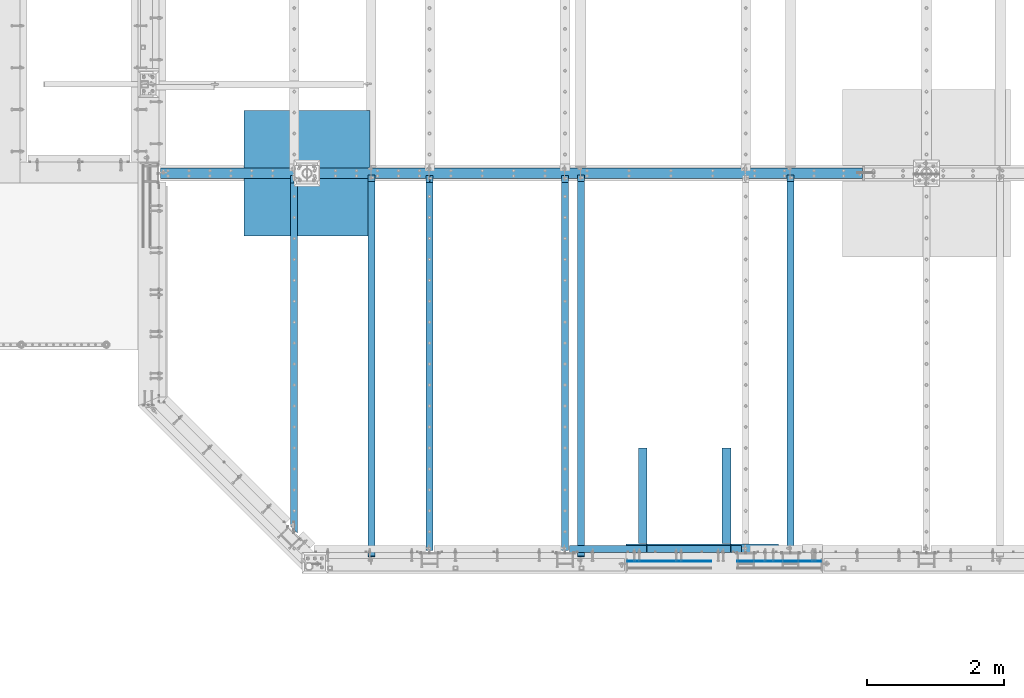
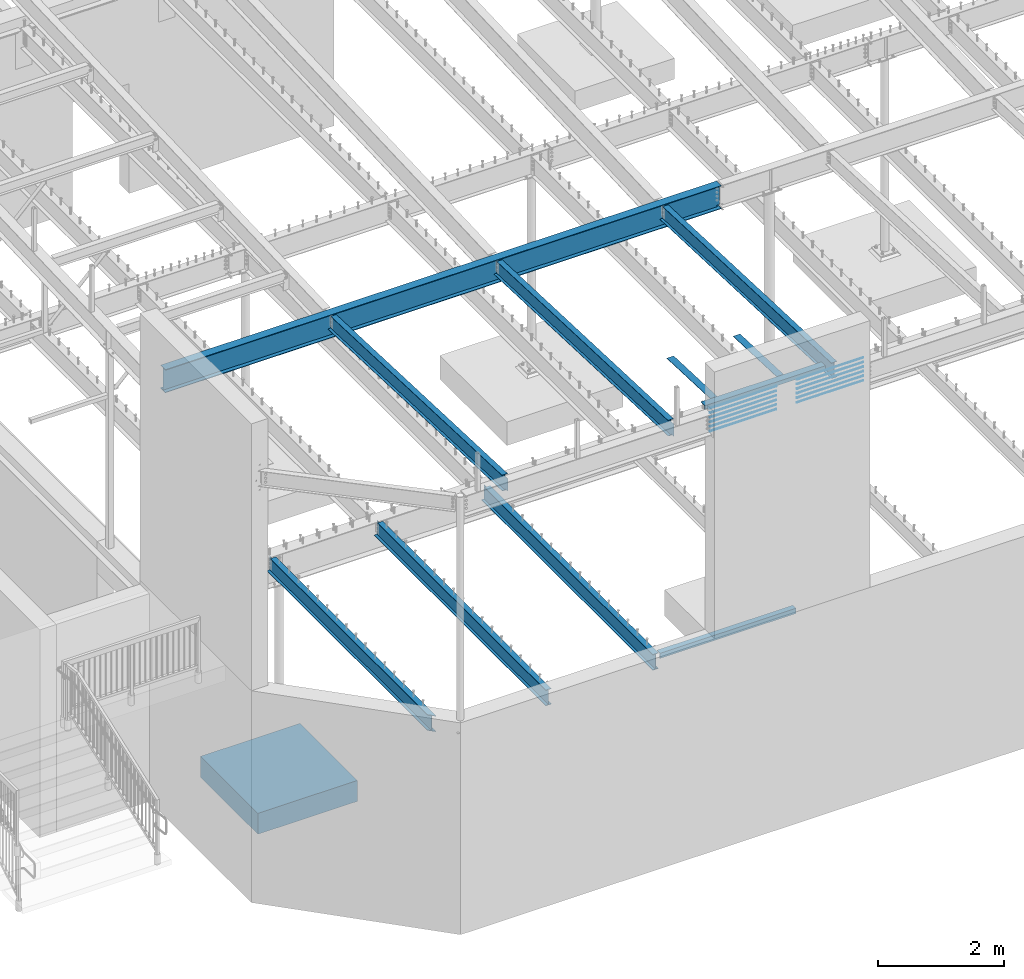
# One storey, part 310 of 975: 24 beams.
"""IFC2X3 building model written with IfcOpenShell, lengths in millimetres."""

from ifc_helpers import new_model, si_unit, frame, origin_with_axes, place, context, subcontext, project, spatial, faceted_brep, material, type_object, element, save


model = new_model("IFC2X3")

# Units and contexts
model_context = context("Model", 3, precision=1e-05, world=origin_with_axes())
body_context = subcontext(model_context, "Body", "Model", "MODEL_VIEW")
ifc_project = project(units=[si_unit("LENGTHUNIT", "METRE", prefix="MILLI"), si_unit("AREAUNIT", "SQUARE_METRE"), si_unit("VOLUMEUNIT", "CUBIC_METRE"), si_unit("MASSUNIT", "GRAM", prefix="KILO"), si_unit("TIMEUNIT", "SECOND"), si_unit("PLANEANGLEUNIT", "RADIAN"), si_unit("SOLIDANGLEUNIT", "STERADIAN"), si_unit("THERMODYNAMICTEMPERATUREUNIT", "DEGREE_CELSIUS"), si_unit("LUMINOUSINTENSITYUNIT", "LUMEN")], contexts=[model_context])

# Site, building, storey
site_placement = place(None, origin_with_axes())
site = spatial("IfcSite", under=ifc_project, at=site_placement, CompositionType="ELEMENT")
building_placement = place(site_placement, origin_with_axes())
building = spatial("IfcBuilding", under=site, at=building_placement, Name="Undefined", CompositionType="ELEMENT")
storey_placement = place(building_placement, origin_with_axes())
storey = spatial("IfcBuildingStorey", under=building, at=storey_placement, Name="Undefined", CompositionType="ELEMENT", Elevation=0.0)

# Beams
ifc_material_1 = material(Name="STEEL/A36")
beam_type_1 = type_object("IfcBeamType", Name="L4X4X5/16", PredefinedType="NOTDEFINED")
beam_1_placement = place(storey_placement, frame((8293.1, 355.6, 3886.2), z_axis=(0.0, 0.0, -1.0), x_axis=(1.0, 0.0, 0.0)))
element("IfcBeam", 1, at=beam_1_placement, inside=storey, type_object=beam_type_1, material=ifc_material_1, Name="LEDGER_ANGLE", ObjectType="L4X4X5/16", context=body_context, shape_type="Brep", body=[
    faceted_brep([(-1.90993887372315e-11, 50.8000000000002, -50.8), (2.00088834390044e-11, 50.8000000000002, 50.8), (2501.9, 50.8, 50.8000000000002), (2501.9, 50.8, -50.8000000000002), (2.00088834390044e-11, 42.8625000000002, 50.8), (2501.9, 42.8625, 50.8000000000002), (-1.63709046319127e-11, 42.8625000000002, -42.8625), (2501.9, 42.8625, -42.8625000000002), (-1.63709046319127e-11, -50.8000000000002, -42.8625), (2501.9, -50.8, -42.8625000000002), (-1.90993887372315e-11, -50.8000000000002, -50.8), (2501.9, -50.8, -50.8000000000002)], [[[0, 1, 2, 3]], [[1, 4, 5, 2]], [[4, 6, 7, 5]], [[6, 8, 9, 7]], [[8, 10, 11, 9]], [[10, 0, 3, 11]], [[5, 7, 9, 11, 3, 2]], [[10, 8, 6, 4, 1, 0]]]),
])
beam_type_2 = type_object("IfcBeamType", Name="L5X3X5/16", PredefinedType="NOTDEFINED")
for number, where, z_axis, x_axis, name in (
    (2, (9359.90074084503, 1826.04382111052, 8358.98196902733), (-0.999999999999998, 6.90000001668524e-08, 0.0), (-8.29999998634476e-08, -0.999194714570452, 0.0401238379827506), "ANGLE"),
    (3, (10579.1004373848, 1826.043922506, 8358.98196901953), (-0.999999999999998, 6.90000001668524e-08, 0.0), (-8.29999998634476e-08, -0.999194714570452, 0.0401238379827506), "ANGLE"),
):
    element("IfcBeam", number, at=place(storey_placement, frame(where, z_axis=z_axis, x_axis=x_axis)), inside=storey, type_object=beam_type_2, material=ifc_material_1, Name=name, ObjectType="L5X3X5/16", context=body_context, shape_type="Brep", body=[
        faceted_brep([(1395.30889729753, 38.1000000012609, 63.5000000006694), (1394.9901576922, 30.1625000012664, 63.5000000006712), (1394.99013793574, 30.1625000011627, -55.5624999993288), (1394.99013661864, 30.1625000322219, -63.4999999993288), (1395.30887618999, 38.1000000011518, -63.4999999993306), (1501.2669859932, 25.8948292101068, -55.562499999276), (1501.2669846761, 25.8948292629557, -63.499999999276), (1513.45074109103, 12.6953416428732, -55.5624999992651), (1513.45073977393, 12.695341695724, -63.4999999992651), (1511.42524778765, -38.0999999987016, -55.5624999992524), (1511.42524647055, -38.0999999987089, -63.4999999992524), (5.0931703299284e-11, -38.0999999999999, -63.5000000000255), (2.27373675443232e-12, -38.1000000000313, -55.5624999999873), (3.41060513164848e-12, 30.1624999999367, -55.5625000000091), (-3.63797880709171e-12, 30.1625000000404, 63.4999999999909), (-4.72937244921923e-11, 38.0999999999999, 63.5000000000182), (5.0931703299284e-11, 38.0999999999999, -63.5000000000255)], [[[0, 1, 2, 3, 4]], [[5, 6, 3, 2]], [[7, 8, 6, 5]], [[9, 10, 8, 7]], [[11, 12, 13, 14, 15, 16]], [[14, 13, 2, 1]], [[15, 14, 1, 0]], [[16, 15, 0, 4]], [[11, 16, 4, 3, 6, 8, 10]], [[12, 11, 10, 9]], [[2, 13, 12, 9, 7, 5]]]),
    ])
beam_2_placement = place(storey_placement, frame((11331.574981802, 368.300247296049, 8420.1), z_axis=(0.0, 1.0, 0.0), x_axis=(-0.999999999999998, 6.90000001668524e-08, 0.0)))
element("IfcBeam", 4, at=beam_2_placement, inside=storey, type_object=beam_type_2, material=ifc_material_1, Name="LEDGER_ANGLE", ObjectType="L5X3X5/16", context=body_context, shape_type="Brep", body=[
    faceted_brep([(5.0931703299284e-11, 38.0999999999999, -63.5000000000255), (-4.72937244921923e-11, 38.0999999999999, 63.5000000000182), (2212.9749747635, 38.1000000000004, 63.4999999999912), (2212.97497476345, 38.1000000000004, -63.5000000000088), (-3.63797880709171e-12, 30.1625000000404, 63.4999999999909), (2212.9749747635, 30.1625000000004, 63.4999999999912), (3.41060513164848e-12, 30.1624999999367, -55.5625000000091), (2212.97497476345, 30.1625000000004, -55.5625000000088), (2.27373675443232e-12, -38.1000000000313, -55.5624999999873), (2212.97497476345, -38.1000000000004, -55.5625000000088), (5.0931703299284e-11, -38.0999999999999, -63.5000000000255), (2212.97497476345, -38.1000000000004, -63.5000000000088)], [[[0, 1, 2, 3]], [[1, 4, 5, 2]], [[4, 6, 7, 5]], [[6, 8, 9, 7]], [[8, 10, 11, 9]], [[10, 0, 3, 11]], [[5, 7, 9, 11, 3, 2]], [[10, 8, 6, 4, 1, 0]]]),
])
ifc_material_2 = material(Name="STEEL/A496")
beam_type_3 = type_object("IfcBeamType", Name="#6 DBA", PredefinedType="NOTDEFINED")
for number, where, z_axis, x_axis, name in (
    (5, (11953.8750023398, 177.800001625287, 8389.94743098933), (0.0, 1.0, 0.0), (-0.999999999999998, 6.90000001668524e-08, 0.0), "ROD"),
    (6, (11953.8750023398, 177.800001607478, 8301.04744311368), (0.0, 1.0, 0.0), (-0.999999999999998, 6.90000001668524e-08, 0.0), "ROD"),
    (7, (11953.8750023398, 177.800001589665, 8212.14745523802), (0.0, 1.0, 0.0), (-0.999999999999998, 6.90000001668524e-08, 0.0), "ROD"),
    (8, (11953.8750023398, 177.800001571856, 8123.24746736236), (0.0, 1.0, 0.0), (-0.999999999999998, 6.90000001668524e-08, 0.0), "ROD"),
    (9, (11953.8750023398, 177.800001554044, 8034.3474794867), (0.0, 1.0, 0.0), (-0.999999999999998, 6.90000001668524e-08, 0.0), "ROD"),
    (10, (11953.8750023398, 177.800001643099, 8478.84741886499), (0.0, 1.0, 0.0), (-0.999999999999998, 6.90000001668524e-08, 0.0), "ROD"),
    (11, (9137.65001562954, 177.799615470926, 8389.94750201357), (0.0, -1.0, 0.0), (1.0, 0.0, 0.0), "ROD"),
    (12, (9137.65001562954, 177.799615488735, 8301.04751413792), (0.0, -1.0, 0.0), (1.0, 0.0, 0.0), "ROD"),
    (13, (9137.65001562954, 177.799615506548, 8212.14752626226), (0.0, -1.0, 0.0), (1.0, 0.0, 0.0), "ROD"),
    (14, (9137.65001562954, 177.799615524357, 8123.2475383866), (0.0, -1.0, 0.0), (1.0, 0.0, 0.0), "ROD"),
    (15, (9137.65001562954, 177.79961554217, 8034.34755051095), (0.0, -1.0, 0.0), (1.0, 0.0, 0.0), "ROD"),
    (16, (9137.6699008948, 177.799615451463, 8478.84748988923), (0.0, -1.0, 0.0), (1.0, 0.0, 0.0), "ROD"),
):
    element("IfcBeam", number, at=place(storey_placement, frame(where, z_axis=z_axis, x_axis=x_axis)), inside=storey, type_object=beam_type_3, material=ifc_material_2, Name=name, ObjectType="#6 DBA", context=body_context, shape_type="Brep", body=[
        faceted_brep([(0.0, -6.34999999998763, -3.63797880709171e-12), (0.0, -4.49012806052269, -4.49012806054634), (1219.19983372321, -4.49012806053543, -4.49012805836537), (1219.19983372321, -6.35000000000036, 2.16823536902666e-09), (0.0, 7.27595761418343e-12, -6.35000000000764), (1219.19983372321, 0.0, -6.34999999783395), (0.0, 4.49012806053724, -4.49012806053906), (1219.19983372321, 4.49012806053543, -4.49012805836537), (0.0, 6.34999999999491, 5.45696821063757e-12), (1219.19983372321, 6.35000000000036, 2.16823536902666e-09), (0.0, 4.49012806052633, 4.49012806054634), (1219.19983372321, 4.49012806053543, 4.49012806270184), (0.0, 0.0, 6.35000000000764), (1219.19983372321, 0.0, 6.35000000216678), (0.0, -4.49012806053361, 4.49012806053543), (1219.19983372321, -4.49012806053543, 4.49012806270184)], [[[0, 1, 2, 3]], [[1, 4, 5, 2]], [[4, 6, 7, 5]], [[6, 8, 9, 7]], [[8, 10, 11, 9]], [[10, 12, 13, 11]], [[12, 14, 15, 13]], [[14, 0, 3, 15]], [[5, 7, 9, 11, 13, 15, 3, 2]], [[14, 12, 10, 8, 6, 4, 1, 0]]]),
    ])
ifc_material_3 = material(Name="STEEL/A992")
beam_type_4 = type_object("IfcBeamType", Name="W12X14", PredefinedType="NOTDEFINED")
beam_3_placement = place(storey_placement, frame((11509.375, 298.74906253854, 8300.36917188875), z_axis=(0.0, 0.0401238250036801, 0.999194715091645), x_axis=(0.0, 0.999194715091645, -0.0401238250036801)))
element("IfcBeam", 17, at=beam_3_placement, inside=storey, type_object=beam_type_4, material=ifc_material_3, Name="BEAM", ObjectType="W12X14", context=body_context, shape_type="Brep", body=[
    faceted_brep([(37.277581501579, -2.38124999999854, -144.462500000039), (37.277581501579, -50.7999999999993, -144.462500000039), (5505.06171865214, -50.7999999999993, -144.462499998078), (5505.06171865214, -2.38125000000036, -144.462499998078), (37.5325731312614, -50.7999999999993, -150.812500000041), (5505.31671028182, -50.7999999999993, -150.812499998081), (37.5325731312614, 50.7999999999993, -150.812500000041), (5505.31671028182, 50.7999999999993, -150.812499998081), (37.277581501579, 50.7999999999993, -144.462500000039), (37.277581501579, 2.38124999999854, -144.462500000039), (5505.06171865214, 2.38125000000036, -144.462499998078), (5505.06171865214, 50.7999999999993, -144.462499998078), (5494.47956601909, 2.38125000000036, 119.062500032711), (5494.47956601909, -2.38125000000036, 119.062500032711), (25.6754623510329, -2.38124999999854, 144.462500000065), (25.6754623510329, -50.7999999999993, 144.462500000065), (25.4204707213506, -50.7999999999993, 150.812500000067), (25.4204707213506, 50.7999999999993, 150.812500000067), (25.6754623510329, 50.7999999999993, 144.462500000065), (25.6754623510329, 2.38124999999854, 144.462500000065), (5403.71671028046, 50.7999999999993, 144.462500001993), (5403.71671028046, 2.38125000000036, 144.462500001993), (5403.71671028046, 2.38125000000036, 131.762499841952), (5404.68344020305, 2.38125000000036, 126.902420323901), (5407.43645410352, 2.38125000000036, 122.782243855745), (5411.55663057168, 2.38125000000036, 120.029229955266), (5416.41671008973, 2.38125000000036, 119.06250003268), (5404.68344020305, -2.38125000000036, 126.902420323901), (5403.71671028046, -2.38125000000036, 131.762499841952), (5407.43645410352, -2.38125000000036, 122.782243855745), (5411.55663057168, -2.38125000000036, 120.029229955266), (5416.41671008973, -2.38125000000036, 119.06250003268), (5403.71671028046, -2.38125000000036, 144.462500001993), (5403.71671028046, -50.7999999999993, 144.462500001993), (5403.71671028046, -50.7999999999993, 150.812500001995), (5403.71671028046, 50.7999999999993, 150.812500001995)], [[[0, 1, 2, 3]], [[1, 4, 5, 2]], [[4, 6, 7, 5]], [[8, 9, 10, 11]], [[3, 2, 5, 7, 11, 10, 12, 13]], [[6, 8, 11, 7]], [[4, 1, 0, 14, 15, 16, 17, 18, 19, 9, 8, 6]], [[19, 18, 20, 21]], [[10, 9, 19, 21, 22, 23, 24, 25, 26, 12]], [[27, 23, 22, 28]], [[29, 24, 23, 27]], [[30, 25, 24, 29]], [[31, 26, 25, 30]], [[13, 12, 26, 31]], [[30, 29, 27, 28, 32, 14, 0, 3, 13, 31]], [[15, 14, 32, 33]], [[16, 15, 33, 34]], [[17, 16, 34, 35]], [[18, 17, 35, 20]], [[34, 33, 32, 28, 22, 21, 20, 35]]]),
])
beam_4_placement = place(storey_placement, frame((8461.375, 95.5756617602171, 8307.50787178829), z_axis=(0.0, 0.039945880990807, 0.999201844770049), x_axis=(0.0, 0.999201844770049, -0.039945880990807)))
element("IfcBeam", 18, at=beam_4_placement, inside=storey, type_object=beam_type_4, material=ifc_material_3, Name="BEAM", ObjectType="W12X14", context=body_context, shape_type="Brep", body=[
    faceted_brep([(62.4236399004201, -2.38125000000036, -119.062500005292), (62.4236402960233, 2.38125000000036, -119.062500005293), (140.53463013612, 2.38125000000036, -119.062500005381), (140.53463013612, -2.38125000000036, -119.062500005381), (145.394709654166, 2.38125000000036, -120.029229927974), (145.394709654166, -2.38125000000036, -120.029229927974), (149.514886122322, 2.38125000000036, -122.782243828455), (149.514886122322, -2.38125000000036, -122.782243828455), (152.267900022804, 2.38125000000036, -126.902420296611), (152.267900022804, -2.38125000000036, -126.902420296611), (153.234629945395, -2.38125000000036, -131.762499814659), (153.234629945395, 2.38125000000036, -131.762499814659), (153.234629945398, 2.38125000000036, -144.46250000013), (153.234629945397, 50.7999999999993, -144.46250000013), (153.234629945398, 50.7999999999993, -150.81250000013), (153.234629945398, -50.7999999999993, -150.81250000013), (153.234629945397, -50.7999999999993, -144.46250000013), (153.234629945397, -2.38125000000036, -144.46250000013), (5606.98626440076, 50.7999999999993, 144.462499995676), (5606.98626440076, 2.38125000000036, 144.462499995676), (153.234629945373, 2.38125000000036, 144.462499999896), (153.234629945373, 50.7999999999993, 144.462499999896), (140.534630136153, -2.38125000000036, 119.06249999471), (140.534630136153, 2.38125000000036, 119.06249999471), (52.9039291776887, 2.38125000000036, 119.06249999471), (52.9039287820855, -2.38125000000036, 119.062499994712), (145.394709654198, -2.38125000000036, 120.029229917291), (145.394709654198, 2.38125000000036, 120.029229917291), (149.51488612235, -2.38125000000036, 122.782243817765), (149.51488612235, 2.38125000000036, 122.782243817765), (152.267900022825, -2.38125000000036, 126.902420285916), (152.267900022825, 2.38125000000036, 126.902420285916), (153.234629945409, -2.38125000000036, 131.762499803961), (153.234629945409, 2.38125000000036, 131.762499803961), (5606.98626440077, -50.7999999999993, 150.812499995676), (5606.98626440077, 50.7999999999993, 150.812499995676), (153.234629945377, 50.7999999999993, 150.812499999898), (153.234629945377, -50.7999999999993, 150.812499810147), (5606.98626440076, -50.7999999999993, 144.462499995676), (153.234629945373, -50.7999999999993, 144.462499999896), (5606.98626440076, -2.38125000000036, 144.462499995676), (153.234629945373, -2.38125000000036, 144.462499999896), (5606.9862644008, -2.38125000000036, 131.762499785807), (5606.9862644008, 2.38125000000036, 131.762499785807), (5607.9529943234, -2.38125000000036, 126.902420267759), (5607.9529943234, 2.38125000000036, 126.902420267759), (5610.70600822388, -2.38125000000036, 122.782243799602), (5610.70600822388, 2.38125000000036, 122.782243799602), (5614.82618469204, -2.38125000000036, 120.029229899115), (5614.82618469204, 2.38125000000036, 120.029229899115), (5619.68626421008, -2.38125000000036, 119.06249997652), (5619.68626421008, 2.38125000000036, 119.06249997652), (5697.79725846631, -2.38125000000036, 119.062499976533), (5697.79725846631, 2.38125000000036, 119.062499976533), (5708.3324054365, -2.38125000000036, -144.46250000443), (5708.3324054365, -50.7999999999993, -144.46250000443), (5708.58626439966, -50.7999999999993, -150.81250000443), (5708.58626439966, 50.7999999999993, -150.81250000443), (5708.3324054365, 50.7999999999993, -144.46250000443), (5708.3324054365, 2.38125000000036, -144.46250000443)], [[[0, 1, 2, 3]], [[3, 2, 4, 5]], [[5, 4, 6, 7]], [[7, 6, 8, 9]], [[10, 11, 12, 13, 14, 15, 16, 17]], [[9, 8, 11, 10]], [[18, 19, 20, 21]], [[22, 23, 24, 25]], [[26, 27, 23, 22]], [[28, 29, 27, 26]], [[30, 31, 29, 28]], [[32, 33, 31, 30]], [[34, 35, 36, 37]], [[38, 34, 37, 39]], [[40, 38, 39, 41]], [[37, 36, 21, 20, 33, 32, 41, 39]], [[35, 18, 21, 36]], [[34, 38, 40, 42, 43, 19, 18, 35]], [[44, 45, 43, 42]], [[46, 47, 45, 44]], [[48, 49, 47, 46]], [[50, 51, 49, 48]], [[52, 53, 51, 50]], [[54, 55, 56, 57, 58, 59, 53, 52]], [[55, 54, 17, 16]], [[56, 55, 16, 15]], [[57, 56, 15, 14]], [[58, 57, 14, 13]], [[59, 58, 13, 12]], [[6, 4, 2, 1, 24, 23, 27, 29, 31, 33, 20, 19, 43, 45, 47, 49, 51, 53, 59, 12, 11, 8]], [[25, 24, 1, 0]], [[54, 52, 50, 48, 46, 44, 42, 40, 41, 32, 30, 28, 26, 22, 25, 0, 3, 5, 7, 9, 10, 17]]]),
])
beam_5_placement = place(storey_placement, frame((5413.375, 95.5756617602171, 8307.50787178829), z_axis=(0.0, 0.039945880990807, 0.999201844770049), x_axis=(0.0, 0.999201844770049, -0.039945880990807)))
element("IfcBeam", 19, at=beam_5_placement, inside=storey, type_object=beam_type_4, material=ifc_material_3, Name="BEAM", ObjectType="W12X14", context=body_context, shape_type="Brep", body=[
    faceted_brep([(62.4238930863233, -2.38125000000036, -119.062500000818), (62.4238934819265, 2.38125000000036, -119.062500000819), (140.534883321403, 2.38125000000036, -119.062500000907), (140.534883321403, -2.38125000000036, -119.062500000907), (145.394962839449, 2.38125000000036, -120.029229923498), (145.394962839449, -2.38125000000036, -120.029229923498), (149.515139307605, 2.38125000000036, -122.782243823979), (149.515139307605, -2.38125000000036, -122.782243823979), (152.268153208086, 2.38125000000036, -126.902420292136), (152.268153208086, -2.38125000000036, -126.902420292136), (153.234883130678, -2.38125000000036, -131.762499810184), (153.234883130678, 2.38125000000036, -131.762499810184), (153.234883130679, 2.38125000000036, -144.462500000131), (153.23488313068, 50.8000000000002, -144.462500000131), (153.234883130681, 50.8000000000002, -150.812500000131), (153.23488313068, -50.8000000000002, -150.812500000131), (153.234883130679, -50.8000000000002, -144.462500000131), (153.23488313068, -2.38125000000036, -144.462500000131), (5606.98626440076, 50.7999999999993, 144.462499995676), (5606.98626440076, 2.38125000000036, 144.462499995676), (153.234883130655, 2.38125000000036, 144.462499999898), (153.234883130655, 50.8000000000002, 144.462499999898), (140.534883321436, -2.38125000000036, 119.062499999187), (140.534883321436, 2.38125000000036, 119.062499999187), (52.9041823635919, 2.38125000000036, 119.062499999187), (52.9041819679886, -2.38125000000036, 119.062499999187), (145.394962839481, -2.38125000000036, 120.029229921767), (145.394962839481, 2.38125000000036, 120.029229921767), (149.515139307633, -2.38125000000036, 122.782243822237), (149.515139307633, 2.38125000000036, 122.782243822237), (152.268153208108, -2.38125000000036, 126.902420290389), (152.268153208108, 2.38125000000036, 126.902420290389), (153.234883130692, -2.38125000000036, 131.762499808436), (153.234883130692, 2.38125000000036, 131.762499808436), (5606.98626440077, -50.7999999999993, 150.812499995676), (5606.98626440077, 50.7999999999993, 150.812499995676), (153.23488313066, 50.8000000000002, 150.812499999898), (153.23488313066, -50.8000000000002, 150.812499810145), (5606.98626440076, -50.7999999999993, 144.462499995676), (153.234883130655, -50.8000000000002, 144.462499999898), (5606.98626440076, -2.38125000000036, 144.462499995676), (153.234883130655, -2.38125000000036, 144.462499999898), (5606.9862644008, -2.38125000000036, 131.762499785807), (5606.9862644008, 2.38125000000036, 131.762499785807), (5607.9529943234, -2.38125000000036, 126.902420267759), (5607.9529943234, 2.38125000000036, 126.902420267759), (5610.70600822388, -2.38125000000036, 122.782243799602), (5610.70600822388, 2.38125000000036, 122.782243799602), (5614.82618469204, -2.38125000000036, 120.029229899115), (5614.82618469204, 2.38125000000036, 120.029229899115), (5619.68626421008, -2.38125000000036, 119.06249997652), (5619.68626421008, 2.38125000000036, 119.06249997652), (5697.79725846631, -2.38125000000036, 119.062499976533), (5697.79725846631, 2.38125000000036, 119.062499976533), (5708.3324054365, -2.38125000000036, -144.46250000443), (5708.3324054365, -50.7999999999993, -144.46250000443), (5708.58626439966, -50.7999999999993, -150.81250000443), (5708.58626439966, 50.7999999999993, -150.81250000443), (5708.3324054365, 50.7999999999993, -144.46250000443), (5708.3324054365, 2.38125000000036, -144.46250000443)], [[[0, 1, 2, 3]], [[3, 2, 4, 5]], [[5, 4, 6, 7]], [[7, 6, 8, 9]], [[10, 11, 12, 13, 14, 15, 16, 17]], [[9, 8, 11, 10]], [[18, 19, 20, 21]], [[22, 23, 24, 25]], [[26, 27, 23, 22]], [[28, 29, 27, 26]], [[30, 31, 29, 28]], [[32, 33, 31, 30]], [[34, 35, 36, 37]], [[38, 34, 37, 39]], [[40, 38, 39, 41]], [[37, 36, 21, 20, 33, 32, 41, 39]], [[35, 18, 21, 36]], [[34, 38, 40, 42, 43, 19, 18, 35]], [[44, 45, 43, 42]], [[46, 47, 45, 44]], [[48, 49, 47, 46]], [[50, 51, 49, 48]], [[52, 53, 51, 50]], [[54, 55, 56, 57, 58, 59, 53, 52]], [[55, 54, 17, 16]], [[56, 55, 16, 15]], [[57, 56, 15, 14]], [[58, 57, 14, 13]], [[59, 58, 13, 12]], [[6, 4, 2, 1, 24, 23, 27, 29, 31, 33, 20, 19, 43, 45, 47, 49, 51, 53, 59, 12, 11, 8]], [[25, 24, 1, 0]], [[54, 52, 50, 48, 46, 44, 42, 40, 41, 32, 30, 28, 26, 22, 25, 0, 3, 5, 7, 9, 10, 17]]]),
])
beam_type_5 = type_object("IfcBeamType", Name="W18X35", PredefinedType="NOTDEFINED")
beam_6_placement = place(storey_placement, frame((2320.92509301436, 5819.775, 8004.175), z_axis=(0.0, 0.0, 1.0), x_axis=(1.0, 0.0, 0.0)))
element("IfcBeam", 20, at=beam_6_placement, inside=storey, type_object=beam_type_5, material=ifc_material_3, Name="BEAM", ObjectType="W18X35", context=body_context, shape_type="Brep", body=[
    faceted_brep([(10249.2969231633, -3.96875, 213.915499496458), (10249.2969231633, 3.96875, 213.915499496458), (10248.8999382805, 3.96875, 214.312499999999), (10248.8999382805, 76.1999999999998, 214.312499999999), (10237.787875523, 76.1999999999998, 225.425), (10237.787875523, -76.1999999999998, 225.425), (10248.8999382805, -76.1999999999998, 214.312499999999), (10248.8999382805, -3.96875, 214.312499999999), (25.3999999999992, -76.1999999999998, -225.425), (25.3999999999992, -76.1999999999998, -214.3125), (25.3999999999992, -3.96875, -214.3125), (25.3999999999992, -3.96875, 214.312499999999), (25.3999999999992, -76.1999999999998, 214.312499999999), (25.3999999999992, -76.1999999999998, 225.425), (25.3999999999992, 76.1999999999998, 225.425), (25.3999999999992, 76.1999999999998, 214.312499999999), (25.3999999999992, 3.96875, 214.312499999999), (25.3999999999992, 3.96875, -214.3125), (25.3999999999992, 76.1999999999998, -214.3125), (25.3999999999992, 76.1999999999998, -225.425), (10237.7878759883, 3.96875, -214.3125), (10237.7878759883, 76.1999999999998, -214.3125), (10248.8999387459, 76.1999999999998, -225.425), (10248.8999387459, -76.1999999999998, -225.425), (10237.7878759883, -76.1999999999998, -214.3125), (10237.7878759883, -3.96875, -214.3125), (10237.3908911055, 3.96875, -213.91549949646), (10237.3908911055, -3.96875, -213.91549949646), (10217.9439075044, 3.96875, -213.91549949646), (10217.9439075044, -3.96875, -213.91549949646), (10199.4566399626, 3.96875, -203.575605287907), (10199.4566399626, -3.96875, -203.575605287907), (10195.3439548054, 3.96875, -198.997422721185), (10195.3439548054, -3.96875, -198.997422721185), (10194.8890964811, 3.96875, -192.860074863893), (10194.8890964811, -3.96875, -192.860074863893), (10198.2819482329, 3.96875, -187.72563314086), (10198.2819482329, -3.96875, -187.72563314086), (10204.1061444376, 3.96875, -185.7375), (10204.1061444376, -3.96875, -185.7375), (10245.7249069856, 3.96875, -185.7375), (10245.7249069856, -3.96875, -185.7375), (10245.7249069856, -3.96875, 185.737499999999), (10245.7249069856, 3.96875, 185.737499999999), (10216.0121431558, 3.96875, 185.737499999999), (10216.0121431558, -3.96875, 185.737499999999), (10210.1879469511, 3.96875, 187.725633140859), (10210.1879469511, -3.96875, 187.725633140859), (10206.7950951994, 3.96875, 192.860074863892), (10206.7950951994, -3.96875, 192.860074863892), (10207.2499535236, 3.96875, 198.997422721183), (10207.2499535236, -3.96875, 198.997422721183), (10211.3626386808, 3.96875, 203.575605287907), (10211.3626386808, -3.96875, 203.575605287907), (10229.8499062227, 3.96875, 213.915499496458), (10229.8499062227, -3.96875, 213.915499496458)], [[[0, 1, 2, 3, 4, 5, 6, 7]], [[8, 9, 10, 11, 12, 13, 14, 15, 16, 17, 18, 19]], [[18, 17, 20, 21]], [[19, 18, 21, 22]], [[8, 19, 22, 23]], [[9, 8, 23, 24]], [[10, 9, 24, 25]], [[23, 22, 21, 20, 26, 27, 25, 24]], [[28, 29, 27, 26]], [[29, 28, 30, 31]], [[31, 30, 32, 33]], [[33, 32, 34, 35]], [[35, 34, 36, 37]], [[37, 36, 38, 39]], [[39, 38, 40, 41]], [[42, 41, 40, 43]], [[44, 45, 42, 43]], [[45, 44, 46, 47]], [[47, 46, 48, 49]], [[49, 48, 50, 51]], [[51, 50, 52, 53]], [[53, 52, 54, 55]], [[11, 10, 25, 27, 29, 31, 33, 35, 37, 39, 41, 42, 45, 47, 49, 51, 53, 55, 0, 7]], [[12, 11, 7, 6]], [[13, 12, 6, 5]], [[14, 13, 5, 4]], [[15, 14, 4, 3]], [[16, 15, 3, 2]], [[54, 52, 50, 48, 46, 44, 43, 40, 38, 36, 34, 32, 30, 28, 26, 20, 17, 16, 2, 1]], [[55, 54, 1, 0]]]),
])
beam_type_6 = type_object("IfcBeamType", Name="W12X19", PredefinedType="NOTDEFINED")
beam_7_placement = place(storey_placement, frame((8229.6, 114.300000000006, 3783.0125), z_axis=(0.0, 0.0, 1.0), x_axis=(0.0, 1.0, 0.0)))
element("IfcBeam", 21, at=beam_7_placement, inside=storey, type_object=beam_type_6, material=ifc_material_3, Name="BEAM", ObjectType="W12X19", context=body_context, shape_type="Brep", body=[
    faceted_brep([(215.899999999996, -3.17499999999927, -144.4625), (215.899999999996, -50.7999999999993, -144.4625), (5674.51874999999, -50.7999999999993, -144.4625), (5674.51874999999, -3.17499999999927, -144.4625), (215.899999999996, -50.7999999999993, -153.9875), (5674.51874999999, -50.7999999999993, -153.9875), (215.899999999996, 50.7999999999993, -153.9875), (5674.51874999999, 50.7999999999993, -153.9875), (215.899999999996, 50.7999999999993, -144.4625), (215.899999999996, 3.17499999999927, -144.4625), (5674.51874999999, 3.17499999999927, -144.4625), (5674.51874999999, 50.7999999999993, -144.4625), (5674.51874999999, 3.17499999999927, 128.5875), (5674.51874999999, -3.17499999999927, 128.5875), (215.899999999996, -3.17499999999927, 144.4625), (215.899999999996, -50.7999999999993, 144.4625), (215.899999999996, -50.7999999999993, 153.9875), (215.899999999996, 50.7999999999993, 153.9875), (215.899999999996, 50.7999999999993, 144.4625), (215.899999999996, 3.17499999999927, 144.4625), (5572.91875, 50.7999999999993, 144.4625), (5572.91875, 3.17499999999927, 144.4625), (5572.91875, 3.17499999999927, 141.287499809265), (5573.88547992258, 3.17499999999927, 136.42742029122), (5576.63849382306, 3.17499999999927, 132.307243823066), (5580.75867029121, 3.17499999999927, 129.554229922588), (5585.61874980926, 3.17499999999927, 128.5875), (5573.88547992258, -3.17499999999927, 136.42742029122), (5572.91875, -3.17499999999927, 141.287499809265), (5576.63849382306, -3.17499999999927, 132.307243823066), (5580.75867029121, -3.17499999999927, 129.554229922588), (5585.61874980926, -3.17499999999927, 128.5875), (5572.91875, -3.17499999999927, 144.4625), (5572.91875, -50.7999999999993, 144.4625), (5572.91875, -50.7999999999993, 153.9875), (5572.91875, 50.7999999999993, 153.9875)], [[[0, 1, 2, 3]], [[1, 4, 5, 2]], [[4, 6, 7, 5]], [[8, 9, 10, 11]], [[3, 2, 5, 7, 11, 10, 12, 13]], [[6, 8, 11, 7]], [[4, 1, 0, 14, 15, 16, 17, 18, 19, 9, 8, 6]], [[19, 18, 20, 21]], [[10, 9, 19, 21, 22, 23, 24, 25, 26, 12]], [[27, 23, 22, 28]], [[29, 24, 23, 27]], [[30, 25, 24, 29]], [[31, 26, 25, 30]], [[13, 12, 26, 31]], [[30, 29, 27, 28, 32, 14, 0, 3, 13, 31]], [[15, 14, 32, 33]], [[16, 15, 33, 34]], [[17, 16, 34, 35]], [[18, 17, 35, 20]], [[34, 33, 32, 28, 22, 21, 20, 35]]]),
])
beam_8_placement = place(storey_placement, frame((6260.04172920507, 114.300000000004, 3783.0125), z_axis=(0.0, 0.0, 1.0), x_axis=(0.0, 1.0, 0.0)))
element("IfcBeam", 22, at=beam_8_placement, inside=storey, type_object=beam_type_6, material=ifc_material_3, Name="BEAM", ObjectType="W12X19", context=body_context, shape_type="Brep", body=[
    faceted_brep([(215.899999999996, -3.17499999999927, -144.4625), (215.899999999996, -50.7999999999993, -144.4625), (5674.51874999999, -50.7999999999993, -144.4625), (5674.51874999999, -3.17499999999927, -144.4625), (215.899999999996, -50.7999999999993, -153.9875), (5674.51874999999, -50.7999999999993, -153.9875), (215.899999999996, 50.7999999999993, -153.9875), (5674.51874999999, 50.7999999999993, -153.9875), (215.899999999996, 50.7999999999993, -144.4625), (215.899999999996, 3.17499999999927, -144.4625), (5674.51874999999, 3.17499999999927, -144.4625), (5674.51874999999, 50.7999999999993, -144.4625), (5674.51874999999, 3.17499999999927, 128.5875), (5674.51874999999, -3.17499999999927, 128.5875), (215.899999999996, -3.17499999999927, 144.4625), (215.899999999996, -50.7999999999993, 144.4625), (215.899999999996, -50.7999999999993, 153.9875), (215.899999999996, 50.7999999999993, 153.9875), (215.899999999996, 50.7999999999993, 144.4625), (215.899999999996, 3.17499999999927, 144.4625), (5572.91875, 50.7999999999993, 144.4625), (5572.91875, 3.17499999999927, 144.4625), (5572.91875, 3.17499999999927, 141.287499809265), (5573.88547992258, 3.17499999999927, 136.42742029122), (5576.63849382306, 3.17499999999927, 132.307243823066), (5580.75867029121, 3.17499999999927, 129.554229922588), (5585.61874980926, 3.17499999999927, 128.5875), (5573.88547992258, -3.17499999999927, 136.42742029122), (5572.91875, -3.17499999999927, 141.287499809265), (5576.63849382306, -3.17499999999927, 132.307243823066), (5580.75867029121, -3.17499999999927, 129.554229922588), (5585.61874980926, -3.17499999999927, 128.5875), (5572.91875, -3.17499999999927, 144.4625), (5572.91875, -50.7999999999993, 144.4625), (5572.91875, -50.7999999999993, 153.9875), (5572.91875, 50.7999999999993, 153.9875)], [[[0, 1, 2, 3]], [[1, 4, 5, 2]], [[4, 6, 7, 5]], [[8, 9, 10, 11]], [[3, 2, 5, 7, 11, 10, 12, 13]], [[6, 8, 11, 7]], [[4, 1, 0, 14, 15, 16, 17, 18, 19, 9, 8, 6]], [[19, 18, 20, 21]], [[10, 9, 19, 21, 22, 23, 24, 25, 26, 12]], [[27, 23, 22, 28]], [[29, 24, 23, 27]], [[30, 25, 24, 29]], [[31, 26, 25, 30]], [[13, 12, 26, 31]], [[30, 29, 27, 28, 32, 14, 0, 3, 13, 31]], [[15, 14, 32, 33]], [[16, 15, 33, 34]], [[17, 16, 34, 35]], [[18, 17, 35, 20]], [[34, 33, 32, 28, 22, 21, 20, 35]]]),
])
beam_9_placement = place(storey_placement, frame((4290.48345841015, 595.094030713674, 3783.0125), z_axis=(0.0, 0.0, 1.0), x_axis=(0.0, 1.0, 0.0)))
element("IfcBeam", 23, at=beam_9_placement, inside=storey, type_object=beam_type_6, material=ifc_material_3, Name="BEAM", ObjectType="W12X19", context=body_context, shape_type="Brep", body=[
    faceted_brep([(32.7460244842782, -3.17500000000018, -144.4625), (-14.8789755157218, -50.8000000000002, -144.4625), (5193.72471928632, -50.8000000000002, -144.4625), (5193.72471928632, -3.17500000000018, -144.4625), (-14.8789755157218, -50.8000000000002, -153.9875), (5193.72471928632, -50.8000000000002, -153.9875), (86.7210244842781, 50.8000000000002, -153.9875), (5193.72471928632, 50.8000000000002, -153.9875), (86.7210244842781, 50.8000000000002, -144.4625), (39.0960244842781, 3.17500000000018, -144.4625), (5193.72471928632, 3.17500000000018, -144.4625), (5193.72471928632, 50.8000000000002, -144.4625), (5193.72471928632, 3.17500000000018, 128.5875), (5193.72471928632, -3.17500000000018, 128.5875), (32.7460244842782, -3.17500000000018, 144.4625), (-14.8789755157218, -50.8000000000002, 144.4625), (-14.8789755157218, -50.8000000000002, 153.9875), (86.7210244842781, 50.8000000000002, 153.9875), (86.7210244842781, 50.8000000000002, 144.4625), (39.0960244842781, 3.17500000000018, 144.4625), (5085.77471928632, 50.8000000000002, 144.4625), (5085.77471928632, 3.17500000000018, 144.4625), (5085.77471928632, 3.17500000000018, 141.287499809265), (5086.74144920891, 3.17500000000018, 136.42742029122), (5089.49446310939, 3.17500000000018, 132.307243823066), (5093.61463957754, 3.17500000000018, 129.554229922588), (5098.47471909559, 3.17500000000018, 128.5875), (5086.74144920891, -3.17500000000018, 136.42742029122), (5085.77471928632, -3.17500000000018, 141.287499809265), (5089.49446310939, -3.17500000000018, 132.307243823066), (5093.61463957754, -3.17500000000018, 129.554229922588), (5098.47471909559, -3.17500000000018, 128.5875), (5085.77471928632, -3.17500000000018, 144.4625), (5085.77471928632, -50.8000000000002, 144.4625), (5085.77471928632, -50.8000000000002, 153.9875), (5085.77471928632, 50.8000000000002, 153.9875)], [[[0, 1, 2, 3]], [[1, 4, 5, 2]], [[4, 6, 7, 5]], [[8, 9, 10, 11]], [[3, 2, 5, 7, 11, 10, 12, 13]], [[6, 8, 11, 7]], [[4, 1, 0, 14, 15, 16, 17, 18, 19, 9, 8, 6]], [[19, 18, 20, 21]], [[10, 9, 19, 21, 22, 23, 24, 25, 26, 12]], [[27, 23, 22, 28]], [[29, 24, 23, 27]], [[30, 25, 24, 29]], [[31, 26, 25, 30]], [[13, 12, 26, 31]], [[30, 29, 27, 28, 32, 14, 0, 3, 13, 31]], [[15, 14, 32, 33]], [[16, 15, 33, 34]], [[17, 16, 34, 35]], [[18, 17, 35, 20]], [[34, 33, 32, 28, 22, 21, 20, 35]]]),
])
ifc_material_4 = material(Name="CONCRETE/5000")
beam_type_7 = type_object("IfcBeamType", PredefinedType="NOTDEFINED")
beam_10_placement = place(storey_placement, frame((3562.35000846572, 5819.775023622, -508.0), z_axis=(0.0, 0.0, 1.0), x_axis=(1.0, 0.0, 0.0)))
element("IfcBeam", 24, at=beam_10_placement, inside=storey, type_object=beam_type_7, material=ifc_material_4, Name="FOOTING", context=body_context, shape_type="Brep", body=[
    faceted_brep([(0.0, 914.400000000001, -203.2), (0.0, 914.400000000001, 203.2), (1828.8, 914.400000000001, 203.2), (1828.8, 914.400000000001, -203.2), (0.0, -914.400000000001, 203.2), (1828.8, -914.400000000001, 203.2), (0.0, -914.400000000001, -203.2), (1828.8, -914.400000000001, -203.2)], [[[0, 1, 2, 3]], [[1, 4, 5, 2]], [[4, 6, 7, 5]], [[6, 0, 3, 7]], [[5, 7, 3, 2]], [[6, 4, 1, 0]]]),
])

save(model, "model.ifc")
